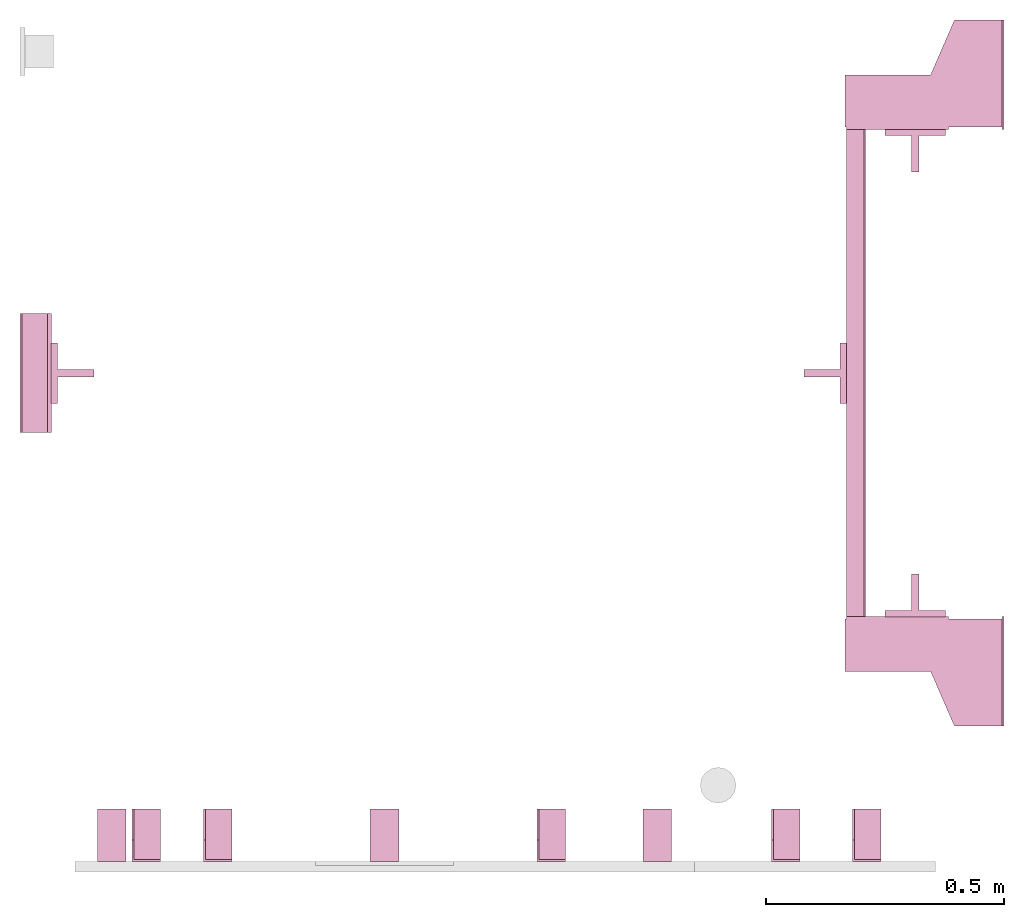
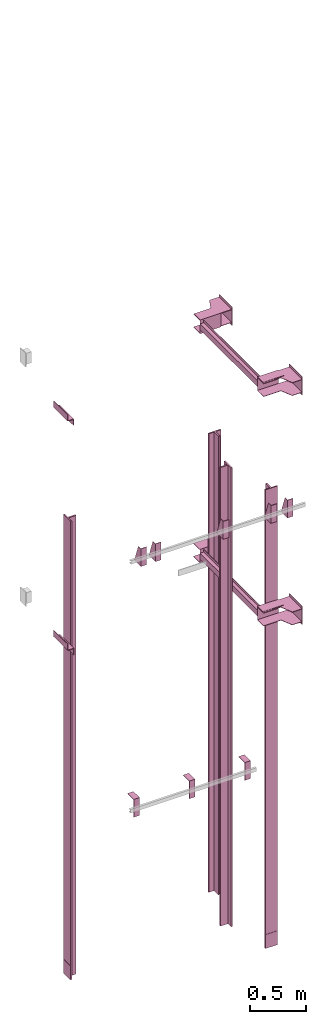
# One storey, part 3 of 3: 16 transport elements.
"""IFC4 building model written with IfcOpenShell, lengths in millimetres."""

from ifc_helpers import new_model, entity, si_unit, converted_unit, frame, origin_with_axes, place, context, subcontext, project, spatial, faceted_brep, element, save


model = new_model("IFC4")

# Units and contexts
context_of_model = context(None, 3, precision=0.01, world=origin_with_axes())
sub_context_1 = subcontext(context_of_model, None, None, "MODEL_VIEW")
sub_context_2 = subcontext(context_of_model, None, None, "MODEL_VIEW")
sub_context_3 = subcontext(context_of_model, None, None, "MODEL_VIEW")
sub_context_4 = subcontext(context_of_model, None, None, "MODEL_VIEW")
sub_context_5 = subcontext(context_of_model, None, None, "MODEL_VIEW")
sub_context_6 = subcontext(context_of_model, None, None, "MODEL_VIEW")
sub_context_7 = subcontext(context_of_model, None, None, "MODEL_VIEW")
sub_context_8 = subcontext(context_of_model, None, None, "MODEL_VIEW")
sub_context_9 = subcontext(context_of_model, None, None, "MODEL_VIEW")
sub_context_10 = subcontext(context_of_model, None, None, "MODEL_VIEW")
sub_context_11 = subcontext(context_of_model, None, None, "MODEL_VIEW")
sub_context_12 = subcontext(context_of_model, None, None, "MODEL_VIEW")
sub_context_13 = subcontext(context_of_model, None, None, "MODEL_VIEW")
sub_context_14 = subcontext(context_of_model, None, None, "MODEL_VIEW")
sub_context_15 = subcontext(context_of_model, None, None, "MODEL_VIEW")
sub_context_16 = subcontext(context_of_model, None, None, "MODEL_VIEW")
ifc_project = project(units=[converted_unit("PLANEANGLEUNIT", "degree", entity("IfcPlaneAngleMeasure", 0.017453292519943), si_unit("PLANEANGLEUNIT", "RADIAN"), dimensions=[0, 0, 0, 0, 0, 0, 0]), si_unit("LENGTHUNIT", "METRE", prefix="MILLI"), si_unit("MASSUNIT", "GRAM", prefix="KILO"), converted_unit("TIMEUNIT", "year", entity("IfcTimeMeasure", 31557600.0), si_unit("TIMEUNIT", "SECOND"), dimensions=[0, 0, 1, 0, 0, 0, 0]), si_unit("THERMODYNAMICTEMPERATUREUNIT", "DEGREE_CELSIUS"), si_unit("AREAUNIT", "SQUARE_METRE"), si_unit("FORCEUNIT", "NEWTON"), si_unit("VOLUMEUNIT", "CUBIC_METRE"), si_unit("PRESSUREUNIT", "PASCAL"), si_unit("SOLIDANGLEUNIT", "STERADIAN")], contexts=[context_of_model])

# Site, building, storey
site = spatial("IfcSite", under=ifc_project)
building = spatial("IfcBuilding", under=site, Name="Document")
placement = place(None, origin_with_axes())
storey_placement = place(placement, frame((0.0, 0.0, -8840.0), z_axis=(0.0, 0.0, 1.0), x_axis=(1.0, 0.0, 0.0)))
storey = spatial("IfcBuildingStorey", under=building, at=storey_placement, Name="-2", Elevation=-8840.0)

# Transport elements
transport_element_1_placement = place(storey_placement, frame((2065.0, 1025.0, 1140.0), z_axis=(0.0, 0.0, 1.0), x_axis=(0.0, 1.0, 0.0)))
element("IfcTransportElement", 1, at=transport_element_1_placement, inside=storey, PredefinedType="ELEVATOR", context=sub_context_1, shape_type="Brep", body=[
    faceted_brep([(-611.0, 331.0, -72.5), (-514.0, 331.0, -72.5), (-514.0, 331.0, 72.5), (-611.0, 331.0, 72.5), (-611.0, 331.0, 75.5), (-511.0, 331.0, 75.5), (-511.0, 331.0, -75.5), (-611.0, 331.0, -75.5), (-511.0, 116.0, -75.5), (-511.0, 116.0, 75.5), (-611.0, 116.0, 75.5), (-611.0, 116.0, 72.5), (-514.0, 116.0, 72.5), (-514.0, 116.0, -72.5), (-611.0, 116.0, -72.5), (-611.0, 116.0, -75.5)], [[[0, 1, 2, 3, 4, 5, 6, 7]], [[8, 9, 10, 11, 12, 13, 14, 15]], [[15, 14, 0, 7]], [[13, 12, 2, 1]], [[5, 9, 8, 6]], [[11, 10, 4, 3]], [[6, 8, 15, 7]], [[14, 13, 1, 0]], [[2, 12, 11, 3]], [[10, 9, 5, 4]]]),
    faceted_brep([(-511.0, 291.0, -32.5), (-511.0, 294.0, -32.5), (-511.0, 294.0, -59.5), (-511.0, 291.0, -59.5), (511.0, 291.0, -32.5), (511.0, 291.0, -59.5), (511.0, 294.0, -59.5), (511.0, 294.0, -32.5)], [[[0, 1, 2, 3]], [[4, 5, 6, 7]], [[0, 3, 5, 4]], [[3, 2, 6, 5]], [[2, 1, 7, 6]], [[1, 0, 4, 7]]]),
    faceted_brep([(-511.0, 291.0, 59.5), (-511.0, 294.0, 59.5), (-511.0, 294.0, 32.5), (-511.0, 291.0, 32.5), (511.0, 291.0, 59.5), (511.0, 291.0, 32.5), (511.0, 294.0, 32.5), (511.0, 294.0, 59.5)], [[[0, 1, 2, 3]], [[4, 5, 6, 7]], [[0, 3, 5, 4]], [[3, 2, 6, 5]], [[2, 1, 7, 6]], [[1, 0, 4, 7]]]),
    faceted_brep([(-511.0, 331.0, 32.5), (511.0, 331.0, 32.5), (511.0, 331.0, -32.5), (-511.0, 331.0, -32.5), (511.0, 328.0, -29.5), (511.0, 328.0, 29.5), (-511.0, 328.0, 29.5), (-511.0, 328.0, -29.5), (511.0, 291.0, -32.5), (511.0, 291.0, -29.5), (-511.0, 291.0, -29.5), (-511.0, 291.0, -32.5), (511.0, 291.0, 29.5), (511.0, 291.0, 32.5), (-511.0, 291.0, 32.5), (-511.0, 291.0, 29.5)], [[[0, 1, 2, 3]], [[4, 5, 6, 7]], [[8, 9, 10, 11]], [[12, 13, 14, 15]], [[11, 10, 7, 6, 15, 14, 0, 3]], [[2, 1, 13, 12, 5, 4, 9, 8]], [[2, 8, 11, 3]], [[10, 9, 4, 7]], [[14, 13, 1, 0]], [[5, 12, 15, 6]]]),
    faceted_brep([(511.0, 331.0, 75.5), (611.0, 331.0, 75.5), (611.0, 331.0, 72.5), (514.0, 331.0, 72.5), (514.0, 331.0, -72.5), (611.0, 331.0, -72.5), (611.0, 331.0, -75.5), (511.0, 331.0, -75.5), (511.0, 116.0, -75.5), (611.0, 116.0, -75.5), (611.0, 116.0, -72.5), (514.0, 116.0, -72.5), (514.0, 116.0, 72.5), (611.0, 116.0, 72.5), (611.0, 116.0, 75.5), (511.0, 116.0, 75.5)], [[[0, 1, 2, 3, 4, 5, 6, 7]], [[8, 9, 10, 11, 12, 13, 14, 15]], [[8, 15, 0, 7]], [[3, 12, 11, 4]], [[5, 10, 9, 6]], [[1, 14, 13, 2]], [[6, 9, 8, 7]], [[11, 10, 5, 4]], [[15, 14, 1, 0]], [[2, 13, 12, 3]]]),
    faceted_brep([(-626.0, 334.0, 72.5), (-516.0, 334.0, 72.5), (-516.0, 334.0, 68.5), (-626.0, 334.0, 68.5), (-516.0, 4.0, 68.5), (-516.0, 4.0, 72.5), (-741.0, 4.0, 72.5), (-741.0, 4.0, 68.5), (-741.0, 104.0, 72.5), (-626.0, 154.0, 72.5), (-626.0, 154.0, 68.5), (-741.0, 104.0, 68.5)], [[[0, 1, 2, 3]], [[4, 5, 6, 7]], [[8, 9, 10, 11]], [[10, 9, 0, 3]], [[1, 5, 4, 2]], [[7, 6, 8, 11]], [[2, 4, 7, 11, 10, 3]], [[9, 8, 6, 5, 1, 0]]]),
    faceted_brep([(516.0, 334.0, 72.5), (626.0, 334.0, 72.5), (626.0, 334.0, 68.5), (516.0, 334.0, 68.5), (741.0, 4.0, 68.5), (741.0, 4.0, 72.5), (516.0, 4.0, 72.5), (516.0, 4.0, 68.5), (626.0, 154.0, 72.5), (741.0, 104.0, 72.5), (741.0, 104.0, 68.5), (626.0, 154.0, 68.5)], [[[0, 1, 2, 3]], [[4, 5, 6, 7]], [[8, 9, 10, 11]], [[7, 6, 0, 3]], [[1, 8, 11, 2]], [[9, 5, 4, 10]], [[2, 11, 10, 4, 7, 3]], [[6, 5, 9, 8, 1, 0]]]),
    faceted_brep([(516.0, 334.0, -68.5), (626.0, 334.0, -68.5), (626.0, 334.0, -72.5), (516.0, 334.0, -72.5), (741.0, 4.0, -72.5), (741.0, 4.0, -68.5), (516.0, 4.0, -68.5), (516.0, 4.0, -72.5), (626.0, 154.0, -68.5), (741.0, 104.0, -68.5), (741.0, 104.0, -72.5), (626.0, 154.0, -72.5)], [[[0, 1, 2, 3]], [[4, 5, 6, 7]], [[8, 9, 10, 11]], [[7, 6, 0, 3]], [[1, 8, 11, 2]], [[9, 5, 4, 10]], [[2, 11, 10, 4, 7, 3]], [[6, 5, 9, 8, 1, 0]]]),
    faceted_brep([(-626.0, 334.0, -68.5), (-516.0, 334.0, -68.5), (-516.0, 334.0, -72.5), (-626.0, 334.0, -72.5), (-516.0, 4.0, -72.5), (-516.0, 4.0, -68.5), (-741.0, 4.0, -68.5), (-741.0, 4.0, -72.5), (-741.0, 104.0, -68.5), (-626.0, 154.0, -68.5), (-626.0, 154.0, -72.5), (-741.0, 104.0, -72.5)], [[[0, 1, 2, 3]], [[4, 5, 6, 7]], [[8, 9, 10, 11]], [[10, 9, 0, 3]], [[1, 5, 4, 2]], [[7, 6, 8, 11]], [[2, 4, 7, 11, 10, 3]], [[9, 8, 6, 5, 1, 0]]]),
    faceted_brep([(-511.0, 0.0, -100.0), (-511.0, 0.0, 100.0), (-741.0, 0.0, 100.0), (-741.0, 0.0, -100.0), (-511.0, 4.0, -100.0), (-741.0, 4.0, -100.0), (-741.0, 4.0, 100.0), (-511.0, 4.0, 100.0)], [[[0, 1, 2, 3]], [[4, 5, 6, 7]], [[0, 3, 5, 4]], [[3, 2, 6, 5]], [[2, 1, 7, 6]], [[1, 0, 4, 7]]]),
    faceted_brep([(741.0, 0.0, -100.0), (741.0, 0.0, 100.0), (511.0, 0.0, 100.0), (511.0, 0.0, -100.0), (741.0, 4.0, -100.0), (511.0, 4.0, -100.0), (511.0, 4.0, 100.0), (741.0, 4.0, 100.0)], [[[0, 1, 2, 3]], [[4, 5, 6, 7]], [[0, 3, 5, 4]], [[3, 2, 6, 5]], [[2, 1, 7, 6]], [[1, 0, 4, 7]]]),
])
transport_element_2_placement = place(storey_placement, frame((2065.0, 1025.0, 3640.0), z_axis=(0.0, 0.0, 1.0), x_axis=(0.0, 1.0, 0.0)))
element("IfcTransportElement", 2, at=transport_element_2_placement, inside=storey, PredefinedType="ELEVATOR", context=sub_context_2, shape_type="Brep", body=[
    faceted_brep([(-611.0, 331.0, -72.5), (-514.0, 331.0, -72.5), (-514.0, 331.0, 72.5), (-611.0, 331.0, 72.5), (-611.0, 331.0, 75.5), (-511.0, 331.0, 75.5), (-511.0, 331.0, -75.5), (-611.0, 331.0, -75.5), (-511.0, 116.0, -75.5), (-511.0, 116.0, 75.5), (-611.0, 116.0, 75.5), (-611.0, 116.0, 72.5), (-514.0, 116.0, 72.5), (-514.0, 116.0, -72.5), (-611.0, 116.0, -72.5), (-611.0, 116.0, -75.5)], [[[0, 1, 2, 3, 4, 5, 6, 7]], [[8, 9, 10, 11, 12, 13, 14, 15]], [[15, 14, 0, 7]], [[13, 12, 2, 1]], [[5, 9, 8, 6]], [[11, 10, 4, 3]], [[6, 8, 15, 7]], [[14, 13, 1, 0]], [[2, 12, 11, 3]], [[10, 9, 5, 4]]]),
    faceted_brep([(-511.0, 331.0, 32.5), (511.0, 331.0, 32.5), (511.0, 331.0, -32.5), (-511.0, 331.0, -32.5), (511.0, 328.0, -29.5), (511.0, 328.0, 29.5), (-511.0, 328.0, 29.5), (-511.0, 328.0, -29.5), (511.0, 291.0, -32.5), (511.0, 291.0, -29.5), (-511.0, 291.0, -29.5), (-511.0, 291.0, -32.5), (511.0, 291.0, 29.5), (511.0, 291.0, 32.5), (-511.0, 291.0, 32.5), (-511.0, 291.0, 29.5)], [[[0, 1, 2, 3]], [[4, 5, 6, 7]], [[8, 9, 10, 11]], [[12, 13, 14, 15]], [[11, 10, 7, 6, 15, 14, 0, 3]], [[2, 1, 13, 12, 5, 4, 9, 8]], [[2, 8, 11, 3]], [[10, 9, 4, 7]], [[14, 13, 1, 0]], [[5, 12, 15, 6]]]),
    faceted_brep([(-511.0, 291.0, -32.5), (-511.0, 294.0, -32.5), (-511.0, 294.0, -59.5), (-511.0, 291.0, -59.5), (511.0, 291.0, -32.5), (511.0, 291.0, -59.5), (511.0, 294.0, -59.5), (511.0, 294.0, -32.5)], [[[0, 1, 2, 3]], [[4, 5, 6, 7]], [[0, 3, 5, 4]], [[3, 2, 6, 5]], [[2, 1, 7, 6]], [[1, 0, 4, 7]]]),
    faceted_brep([(-511.0, 291.0, 59.5), (-511.0, 294.0, 59.5), (-511.0, 294.0, 32.5), (-511.0, 291.0, 32.5), (511.0, 291.0, 59.5), (511.0, 291.0, 32.5), (511.0, 294.0, 32.5), (511.0, 294.0, 59.5)], [[[0, 1, 2, 3]], [[4, 5, 6, 7]], [[0, 3, 5, 4]], [[3, 2, 6, 5]], [[2, 1, 7, 6]], [[1, 0, 4, 7]]]),
    faceted_brep([(511.0, 331.0, 75.5), (611.0, 331.0, 75.5), (611.0, 331.0, 72.5), (514.0, 331.0, 72.5), (514.0, 331.0, -72.5), (611.0, 331.0, -72.5), (611.0, 331.0, -75.5), (511.0, 331.0, -75.5), (511.0, 116.0, -75.5), (611.0, 116.0, -75.5), (611.0, 116.0, -72.5), (514.0, 116.0, -72.5), (514.0, 116.0, 72.5), (611.0, 116.0, 72.5), (611.0, 116.0, 75.5), (511.0, 116.0, 75.5)], [[[0, 1, 2, 3, 4, 5, 6, 7]], [[8, 9, 10, 11, 12, 13, 14, 15]], [[8, 15, 0, 7]], [[3, 12, 11, 4]], [[5, 10, 9, 6]], [[1, 14, 13, 2]], [[6, 9, 8, 7]], [[11, 10, 5, 4]], [[15, 14, 1, 0]], [[2, 13, 12, 3]]]),
    faceted_brep([(516.0, 334.0, -68.5), (626.0, 334.0, -68.5), (626.0, 334.0, -72.5), (516.0, 334.0, -72.5), (741.0, 4.0, -72.5), (741.0, 4.0, -68.5), (516.0, 4.0, -68.5), (516.0, 4.0, -72.5), (626.0, 154.0, -68.5), (741.0, 104.0, -68.5), (741.0, 104.0, -72.5), (626.0, 154.0, -72.5)], [[[0, 1, 2, 3]], [[4, 5, 6, 7]], [[8, 9, 10, 11]], [[7, 6, 0, 3]], [[1, 8, 11, 2]], [[9, 5, 4, 10]], [[2, 11, 10, 4, 7, 3]], [[6, 5, 9, 8, 1, 0]]]),
    faceted_brep([(516.0, 334.0, 72.5), (626.0, 334.0, 72.5), (626.0, 334.0, 68.5), (516.0, 334.0, 68.5), (741.0, 4.0, 68.5), (741.0, 4.0, 72.5), (516.0, 4.0, 72.5), (516.0, 4.0, 68.5), (626.0, 154.0, 72.5), (741.0, 104.0, 72.5), (741.0, 104.0, 68.5), (626.0, 154.0, 68.5)], [[[0, 1, 2, 3]], [[4, 5, 6, 7]], [[8, 9, 10, 11]], [[7, 6, 0, 3]], [[1, 8, 11, 2]], [[9, 5, 4, 10]], [[2, 11, 10, 4, 7, 3]], [[6, 5, 9, 8, 1, 0]]]),
    faceted_brep([(-626.0, 334.0, -68.5), (-516.0, 334.0, -68.5), (-516.0, 334.0, -72.5), (-626.0, 334.0, -72.5), (-516.0, 4.0, -72.5), (-516.0, 4.0, -68.5), (-741.0, 4.0, -68.5), (-741.0, 4.0, -72.5), (-741.0, 104.0, -68.5), (-626.0, 154.0, -68.5), (-626.0, 154.0, -72.5), (-741.0, 104.0, -72.5)], [[[0, 1, 2, 3]], [[4, 5, 6, 7]], [[8, 9, 10, 11]], [[10, 9, 0, 3]], [[1, 5, 4, 2]], [[7, 6, 8, 11]], [[2, 4, 7, 11, 10, 3]], [[9, 8, 6, 5, 1, 0]]]),
    faceted_brep([(-626.0, 334.0, 72.5), (-516.0, 334.0, 72.5), (-516.0, 334.0, 68.5), (-626.0, 334.0, 68.5), (-516.0, 4.0, 68.5), (-516.0, 4.0, 72.5), (-741.0, 4.0, 72.5), (-741.0, 4.0, 68.5), (-741.0, 104.0, 72.5), (-626.0, 154.0, 72.5), (-626.0, 154.0, 68.5), (-741.0, 104.0, 68.5)], [[[0, 1, 2, 3]], [[4, 5, 6, 7]], [[8, 9, 10, 11]], [[10, 9, 0, 3]], [[1, 5, 4, 2]], [[7, 6, 8, 11]], [[2, 4, 7, 11, 10, 3]], [[9, 8, 6, 5, 1, 0]]]),
    faceted_brep([(-511.0, 0.0, -100.0), (-511.0, 0.0, 100.0), (-741.0, 0.0, 100.0), (-741.0, 0.0, -100.0), (-511.0, 4.0, -100.0), (-741.0, 4.0, -100.0), (-741.0, 4.0, 100.0), (-511.0, 4.0, 100.0)], [[[0, 1, 2, 3]], [[4, 5, 6, 7]], [[0, 3, 5, 4]], [[3, 2, 6, 5]], [[2, 1, 7, 6]], [[1, 0, 4, 7]]]),
    faceted_brep([(741.0, 0.0, -100.0), (741.0, 0.0, 100.0), (511.0, 0.0, 100.0), (511.0, 0.0, -100.0), (741.0, 4.0, -100.0), (511.0, 4.0, -100.0), (511.0, 4.0, 100.0), (741.0, 4.0, 100.0)], [[[0, 1, 2, 3]], [[4, 5, 6, 7]], [[0, 3, 5, 4]], [[3, 2, 6, 5]], [[2, 1, 7, 6]], [[1, 0, 4, 7]]]),
])
transport_element_3_placement = place(storey_placement, frame((1879.0, 558.5, -47.0), z_axis=(0.0, -1.0, 0.0), x_axis=(0.0, 0.0, -1.0)))
element("IfcTransportElement", 3, at=transport_element_3_placement, inside=storey, ObjectType="Guide Rail", PredefinedType="ELEVATOR", context=sub_context_3, shape_type="Brep", body=[
    faceted_brep([(2347.5, -63.5, 45.0), (2347.5, 63.5, 45.0), (2347.5, 63.5, 44.0), (2347.5, -63.5, 44.0), (2500.0, -63.5, 45.0), (2500.0, -63.5, 44.0), (2500.0, 63.5, 44.0), (2500.0, 63.5, 45.0)], [[[0, 1, 2, 3]], [[4, 5, 6, 7]], [[0, 3, 5, 4]], [[3, 2, 6, 5]], [[2, 1, 7, 6]], [[1, 0, 4, 7]]]),
    faceted_brep([(-2500.0, -63.5, 45.0), (-2500.0, 63.5, 45.0), (-2500.0, 63.5, 44.0), (-2500.0, -63.5, 44.0), (-2347.5, -63.5, 45.0), (-2347.5, -63.5, 44.0), (-2347.5, 63.5, 44.0), (-2347.5, 63.5, 45.0)], [[[0, 1, 2, 3]], [[4, 5, 6, 7]], [[0, 3, 5, 4]], [[3, 2, 6, 5]], [[2, 1, 7, 6]], [[1, 0, 4, 7]]]),
    faceted_brep([(-2500.0, -63.5, 44.5), (-2500.0, -63.5, 31.79998779296875), (2500.0, -63.5, 31.79998779296875), (2500.0, -63.5, 44.5), (-2500.0, -7.93994140625, 31.79998779296875), (-2500.0, -7.93994140625, -44.5), (2500.0, -7.93994140625, -44.5), (2500.0, -7.93994140625, 31.79998779296875), (2500.0, 7.93994140625, -44.5), (-2500.0, 7.93994140625, -44.5), (-2500.0, 7.93994140625, 31.79998779296875), (2500.0, 7.93994140625, 31.79998779296875), (2500.0, 63.5, 31.79998779296875), (-2500.0, 63.5, 31.79998779296875), (-2500.0, 63.5, 44.5), (2500.0, 63.5, 44.5)], [[[0, 1, 2, 3]], [[4, 5, 6, 7]], [[8, 9, 10, 11]], [[12, 13, 14, 15]], [[15, 14, 0, 3]], [[1, 4, 7, 2]], [[10, 13, 12, 11]], [[5, 9, 8, 6]], [[2, 7, 6, 8, 11, 12, 15, 3]], [[14, 13, 10, 9, 5, 4, 1, 0]]]),
])
transport_element_4_placement = place(storey_placement, frame((1879.0, 1491.5, -47.0), z_axis=(0.0, 1.0, 0.0), x_axis=(0.0, 0.0, 1.0)))
element("IfcTransportElement", 4, at=transport_element_4_placement, inside=storey, ObjectType="Guide Rail", PredefinedType="ELEVATOR", context=sub_context_4, shape_type="Brep", body=[
    faceted_brep([(-2500.0, -63.5, 45.0), (-2500.0, 63.5, 45.0), (-2500.0, 63.5, 44.0), (-2500.0, -63.5, 44.0), (-2347.5, -63.5, 45.0), (-2347.5, -63.5, 44.0), (-2347.5, 63.5, 44.0), (-2347.5, 63.5, 45.0)], [[[0, 1, 2, 3]], [[4, 5, 6, 7]], [[0, 3, 5, 4]], [[3, 2, 6, 5]], [[2, 1, 7, 6]], [[1, 0, 4, 7]]]),
    faceted_brep([(2347.5, -63.5, 45.0), (2347.5, 63.5, 45.0), (2347.5, 63.5, 44.0), (2347.5, -63.5, 44.0), (2500.0, -63.5, 45.0), (2500.0, -63.5, 44.0), (2500.0, 63.5, 44.0), (2500.0, 63.5, 45.0)], [[[0, 1, 2, 3]], [[4, 5, 6, 7]], [[0, 3, 5, 4]], [[3, 2, 6, 5]], [[2, 1, 7, 6]], [[1, 0, 4, 7]]]),
    faceted_brep([(2500.0, -63.5, 31.800048828125), (2500.0, -63.5, 44.5), (-2500.0, -63.5, 44.5), (-2500.0, -63.5, 31.800048828125), (2500.0, -7.93994140625, -44.5), (2500.0, -7.93994140625, 31.800048828125), (-2500.0, -7.93994140625, 31.800048828125), (-2500.0, -7.93994140625, -44.5), (-2500.0, 7.93994140625, 31.800048828125), (2500.0, 7.93994140625, 31.800048828125), (2500.0, 7.93994140625, -44.5), (-2500.0, 7.93994140625, -44.5), (-2500.0, 63.5, 44.5), (2500.0, 63.5, 44.5), (2500.0, 63.5, 31.800048828125), (-2500.0, 63.5, 31.800048828125)], [[[0, 1, 2, 3]], [[4, 5, 6, 7]], [[8, 9, 10, 11]], [[12, 13, 14, 15]], [[6, 5, 0, 3]], [[1, 13, 12, 2]], [[11, 10, 4, 7]], [[9, 8, 15, 14]], [[2, 12, 15, 8, 11, 7, 6, 3]], [[5, 4, 10, 9, 14, 13, 1, 0]]]),
])
transport_element_5_placement = place(storey_placement, frame((110.5, 1025.0, -47.0), z_axis=(-1.0, 0.0, 0.0), x_axis=(0.0, 0.0, -1.0)))
element("IfcTransportElement", 5, at=transport_element_5_placement, inside=storey, ObjectType="Guide Rail", PredefinedType="ELEVATOR", context=sub_context_5, shape_type="Brep", body=[
    faceted_brep([(2347.5, -63.5, 45.0), (2347.5, 63.5, 45.0), (2347.5, 63.5, 44.0), (2347.5, -63.5, 44.0), (2500.0, -63.5, 45.0), (2500.0, -63.5, 44.0), (2500.0, 63.5, 44.0), (2500.0, 63.5, 45.0)], [[[0, 1, 2, 3]], [[4, 5, 6, 7]], [[0, 3, 5, 4]], [[3, 2, 6, 5]], [[2, 1, 7, 6]], [[1, 0, 4, 7]]]),
    faceted_brep([(-2500.0, -63.5, 45.0), (-2500.0, 63.5, 45.0), (-2500.0, 63.5, 44.0), (-2500.0, -63.5, 44.0), (-2347.5, -63.5, 45.0), (-2347.5, -63.5, 44.0), (-2347.5, 63.5, 44.0), (-2347.5, 63.5, 45.0)], [[[0, 1, 2, 3]], [[4, 5, 6, 7]], [[0, 3, 5, 4]], [[3, 2, 6, 5]], [[2, 1, 7, 6]], [[1, 0, 4, 7]]]),
    faceted_brep([(-2500.0, 63.5, 44.5), (-2500.0, -63.5, 44.5), (2500.0, -63.5, 44.5), (2500.0, 63.5, 44.5), (2500.0, 7.94000244140625, 31.800003051757812), (-2500.0, 7.94000244140625, 31.800003051757812), (-2500.0, 63.5, 31.79998779296875), (2500.0, 63.5, 31.79998779296875), (2500.0, -63.5, 31.79998779296875), (-2500.0, -63.5, 31.79998779296875), (-2500.0, -7.93994140625, 31.79998779296875), (2500.0, -7.93994140625, 31.79998779296875), (2500.0, -7.93994140625, -44.5), (-2500.0, -7.93994140625, -44.5), (-2500.0, 7.94000244140625, -44.5), (2500.0, 7.94000244140625, -44.5)], [[[0, 1, 2, 3]], [[4, 5, 6, 7]], [[8, 9, 10, 11]], [[12, 13, 14, 15]], [[7, 6, 0, 3]], [[15, 14, 5, 4]], [[10, 13, 12, 11]], [[1, 9, 8, 2]], [[2, 8, 11, 12, 15, 4, 7, 3]], [[6, 5, 14, 13, 10, 9, 1, 0]]]),
])
transport_element_6_placement = place(storey_placement, frame((1689.5, 1025.0, -47.0), z_axis=(1.0, 0.0, 0.0), x_axis=(0.0, 0.0, 1.0)))
element("IfcTransportElement", 6, at=transport_element_6_placement, inside=storey, ObjectType="Guide Rail", PredefinedType="ELEVATOR", context=sub_context_6, shape_type="Brep", body=[
    faceted_brep([(2347.5, -63.5, 45.0), (2347.5, 63.5, 45.0), (2347.5, 63.5, 44.0), (2347.5, -63.5, 44.0), (2500.0, -63.5, 45.0), (2500.0, -63.5, 44.0), (2500.0, 63.5, 44.0), (2500.0, 63.5, 45.0)], [[[0, 1, 2, 3]], [[4, 5, 6, 7]], [[0, 3, 5, 4]], [[3, 2, 6, 5]], [[2, 1, 7, 6]], [[1, 0, 4, 7]]]),
    faceted_brep([(-2500.0, -63.5, 45.0), (-2500.0, 63.5, 45.0), (-2500.0, 63.5, 44.0), (-2500.0, -63.5, 44.0), (-2347.5, -63.5, 45.0), (-2347.5, -63.5, 44.0), (-2347.5, 63.5, 44.0), (-2347.5, 63.5, 45.0)], [[[0, 1, 2, 3]], [[4, 5, 6, 7]], [[0, 3, 5, 4]], [[3, 2, 6, 5]], [[2, 1, 7, 6]], [[1, 0, 4, 7]]]),
    faceted_brep([(2500.0, 7.94000244140625, -44.5), (2500.0, -7.93994140625, -44.5), (-2500.0, -7.93994140625, -44.5), (-2500.0, 7.94000244140625, -44.5), (2500.0, 63.5, 31.800048828125), (2500.0, 7.94000244140625, 31.800048828125), (-2500.0, 7.94000244140625, 31.800048828125), (-2500.0, 63.5, 31.800048828125), (-2500.0, -63.5, 44.5), (2500.0, -63.5, 44.5), (2500.0, 63.5, 44.5), (-2500.0, 63.5, 44.5), (2500.0, -7.93994140625, 31.800048828125), (2500.0, -63.5, 31.800048828125), (-2500.0, -63.5, 31.800048828125), (-2500.0, -7.93994140625, 31.800048828125)], [[[0, 1, 2, 3]], [[4, 5, 6, 7]], [[8, 9, 10, 11]], [[12, 13, 14, 15]], [[6, 5, 0, 3]], [[1, 12, 15, 2]], [[11, 10, 4, 7]], [[13, 9, 8, 14]], [[2, 15, 14, 8, 11, 7, 6, 3]], [[5, 4, 10, 9, 13, 12, 1, 0]]]),
])
transport_element_7_placement = place(storey_placement, frame((265.0, 0.0, 2580.0), z_axis=(0.0, 0.0, 1.0), x_axis=(1.0, 0.0, 0.0)))
element("IfcTransportElement", 7, at=transport_element_7_placement, inside=storey, PredefinedType="ELEVATOR", context=sub_context_7, shape_type="Brep", body=[
    faceted_brep([(-30.0, 0.0, -97.0), (-30.0, 0.0, 97.0), (-30.0, 4.0, 97.0), (-30.0, 4.0, -93.0), (-30.0, 110.0, -93.0), (-30.0, 110.0, -97.0), (30.0, 110.0, -97.0), (30.0, 110.0, -93.0), (30.0, 4.0, -93.0), (30.0, 4.0, 97.0), (30.0, 0.0, 97.0), (30.0, 0.0, -97.0)], [[[0, 1, 2, 3, 4, 5]], [[6, 7, 8, 9, 10, 11]], [[11, 10, 1, 0]], [[2, 9, 8, 3]], [[4, 7, 6, 5]], [[5, 6, 11, 0]], [[8, 7, 4, 3]], [[10, 9, 2, 1]]]),
    faceted_brep([(-30.0, 4.0, -93.0), (-30.0, 4.0, 97.0), (-30.0, 45.0, 97.0), (-30.0, 110.0, -82.0), (-30.0, 110.0, -93.0), (-26.0, 4.0, -93.0), (-26.0, 110.0, -93.0), (-26.0, 110.0, -82.0), (-26.0, 45.0, 97.0), (-26.0, 4.0, 97.0)], [[[0, 1, 2, 3, 4]], [[5, 6, 7, 8, 9]], [[5, 0, 4, 6]], [[6, 4, 3, 7]], [[7, 3, 2, 8]], [[8, 2, 1, 9]], [[9, 1, 0, 5]]]),
])
transport_element_8_placement = place(storey_placement, frame((415.0, 0.0, 2580.0), z_axis=(0.0, 0.0, 1.0), x_axis=(1.0, 0.0, 0.0)))
element("IfcTransportElement", 8, at=transport_element_8_placement, inside=storey, PredefinedType="ELEVATOR", context=sub_context_8, shape_type="Brep", body=[
    faceted_brep([(-30.0, 0.0, -97.0), (-30.0, 0.0, 97.0), (-30.0, 4.0, 97.0), (-30.0, 4.0, -93.0), (-30.0, 110.0, -93.0), (-30.0, 110.0, -97.0), (30.0, 110.0, -97.0), (30.0, 110.0, -93.0), (30.0, 4.0, -93.0), (30.0, 4.0, 97.0), (30.0, 0.0, 97.0), (30.0, 0.0, -97.0)], [[[0, 1, 2, 3, 4, 5]], [[6, 7, 8, 9, 10, 11]], [[11, 10, 1, 0]], [[2, 9, 8, 3]], [[4, 7, 6, 5]], [[5, 6, 11, 0]], [[8, 7, 4, 3]], [[10, 9, 2, 1]]]),
    faceted_brep([(-30.0, 4.0, -93.0), (-30.0, 4.0, 97.0), (-30.0, 45.0, 97.0), (-30.0, 110.0, -82.0), (-30.0, 110.0, -93.0), (-26.0, 4.0, -93.0), (-26.0, 110.0, -93.0), (-26.0, 110.0, -82.0), (-26.0, 45.0, 97.0), (-26.0, 4.0, 97.0)], [[[0, 1, 2, 3, 4]], [[5, 6, 7, 8, 9]], [[5, 0, 4, 6]], [[6, 4, 3, 7]], [[7, 3, 2, 8]], [[8, 2, 1, 9]], [[9, 1, 0, 5]]]),
])
transport_element_9_placement = place(storey_placement, frame((1115.0, 0.0, 2580.0), z_axis=(0.0, 0.0, 1.0), x_axis=(1.0, 0.0, 0.0)))
element("IfcTransportElement", 9, at=transport_element_9_placement, inside=storey, PredefinedType="ELEVATOR", context=sub_context_9, shape_type="Brep", body=[
    faceted_brep([(-30.0, 0.0, -97.0), (-30.0, 0.0, 97.0), (-30.0, 4.0, 97.0), (-30.0, 4.0, -93.0), (-30.0, 110.0, -93.0), (-30.0, 110.0, -97.0), (30.0, 110.0, -97.0), (30.0, 110.0, -93.0), (30.0, 4.0, -93.0), (30.0, 4.0, 97.0), (30.0, 0.0, 97.0), (30.0, 0.0, -97.0)], [[[0, 1, 2, 3, 4, 5]], [[6, 7, 8, 9, 10, 11]], [[11, 10, 1, 0]], [[2, 9, 8, 3]], [[4, 7, 6, 5]], [[5, 6, 11, 0]], [[8, 7, 4, 3]], [[10, 9, 2, 1]]]),
    faceted_brep([(-30.0, 4.0, -93.0), (-30.0, 4.0, 97.0), (-30.0, 45.0, 97.0), (-30.0, 110.0, -82.0), (-30.0, 110.0, -93.0), (-26.0, 4.0, -93.0), (-26.0, 110.0, -93.0), (-26.0, 110.0, -82.0), (-26.0, 45.0, 97.0), (-26.0, 4.0, 97.0)], [[[0, 1, 2, 3, 4]], [[5, 6, 7, 8, 9]], [[5, 0, 4, 6]], [[6, 4, 3, 7]], [[7, 3, 2, 8]], [[8, 2, 1, 9]], [[9, 1, 0, 5]]]),
])
transport_element_10_placement = place(storey_placement, frame((1607.0, 0.0, 2580.0), z_axis=(0.0, 0.0, 1.0), x_axis=(1.0, 0.0, 0.0)))
element("IfcTransportElement", 10, at=transport_element_10_placement, inside=storey, PredefinedType="ELEVATOR", context=sub_context_10, shape_type="Brep", body=[
    faceted_brep([(-30.0, 4.0, -93.0), (-30.0, 4.0, 97.0), (-30.0, 45.0, 97.0), (-30.0, 110.0, -82.0), (-30.0, 110.0, -93.0), (-26.0, 4.0, -93.0), (-26.0, 110.0, -93.0), (-26.0, 110.0, -82.0), (-26.0, 45.0, 97.0), (-26.0, 4.0, 97.0)], [[[0, 1, 2, 3, 4]], [[5, 6, 7, 8, 9]], [[5, 0, 4, 6]], [[6, 4, 3, 7]], [[7, 3, 2, 8]], [[8, 2, 1, 9]], [[9, 1, 0, 5]]]),
    faceted_brep([(-30.0, 0.0, -97.0), (-30.0, 0.0, 97.0), (-30.0, 4.0, 97.0), (-30.0, 4.0, -93.0), (-30.0, 110.0, -93.0), (-30.0, 110.0, -97.0), (30.0, 110.0, -97.0), (30.0, 110.0, -93.0), (30.0, 4.0, -93.0), (30.0, 4.0, 97.0), (30.0, 0.0, 97.0), (30.0, 0.0, -97.0)], [[[0, 1, 2, 3, 4, 5]], [[6, 7, 8, 9, 10, 11]], [[11, 10, 1, 0]], [[2, 9, 8, 3]], [[4, 7, 6, 5]], [[5, 6, 11, 0]], [[8, 7, 4, 3]], [[10, 9, 2, 1]]]),
])
transport_element_11_placement = place(storey_placement, frame((1777.0, 0.0, 2580.0), z_axis=(0.0, 0.0, 1.0), x_axis=(1.0, 0.0, 0.0)))
element("IfcTransportElement", 11, at=transport_element_11_placement, inside=storey, PredefinedType="ELEVATOR", context=sub_context_11, shape_type="Brep", body=[
    faceted_brep([(-30.0, 0.0, -97.0), (-30.0, 0.0, 97.0), (-30.0, 4.0, 97.0), (-30.0, 4.0, -93.0), (-30.0, 110.0, -93.0), (-30.0, 110.0, -97.0), (30.0, 110.0, -97.0), (30.0, 110.0, -93.0), (30.0, 4.0, -93.0), (30.0, 4.0, 97.0), (30.0, 0.0, 97.0), (30.0, 0.0, -97.0)], [[[0, 1, 2, 3, 4, 5]], [[6, 7, 8, 9, 10, 11]], [[11, 10, 1, 0]], [[2, 9, 8, 3]], [[4, 7, 6, 5]], [[5, 6, 11, 0]], [[8, 7, 4, 3]], [[10, 9, 2, 1]]]),
    faceted_brep([(-30.0, 4.0, -93.0), (-30.0, 4.0, 97.0), (-30.0, 45.0, 97.0), (-30.0, 110.0, -82.0), (-30.0, 110.0, -93.0), (-26.0, 4.0, -93.0), (-26.0, 110.0, -93.0), (-26.0, 110.0, -82.0), (-26.0, 45.0, 97.0), (-26.0, 4.0, 97.0)], [[[0, 1, 2, 3, 4]], [[5, 6, 7, 8, 9]], [[5, 0, 4, 6]], [[6, 4, 3, 7]], [[7, 3, 2, 8]], [[8, 2, 1, 9]], [[9, 1, 0, 5]]]),
])
transport_element_12_placement = place(storey_placement, frame((1337.5, 0.0, -30.0), z_axis=(0.0, 0.0, -1.0), x_axis=(-1.0, 0.0, 0.0)))
element("IfcTransportElement", 12, at=transport_element_12_placement, inside=storey, PredefinedType="ELEVATOR", context=sub_context_12, shape_type="Brep", body=[
    faceted_brep([(-30.0, 4.0, 4.0), (-30.0, 4.0, 194.0), (-30.0, 45.0, 194.0), (-30.0, 110.0, 15.0), (-30.0, 110.0, 4.0), (-26.0, 4.0, 4.0), (-26.0, 110.0, 4.0), (-26.0, 110.0, 15.0), (-26.0, 45.0, 194.0), (-26.0, 4.0, 194.0)], [[[0, 1, 2, 3, 4]], [[5, 6, 7, 8, 9]], [[5, 0, 4, 6]], [[6, 4, 3, 7]], [[7, 3, 2, 8]], [[8, 2, 1, 9]], [[9, 1, 0, 5]]]),
    faceted_brep([(30.0, 0.0, 0.0), (30.0, 110.0, 0.0), (30.0, 110.0, 4.0), (30.0, 4.0, 4.0), (30.0, 4.0, 194.0), (30.0, 0.0, 194.0), (-30.0, 4.0, 194.0), (-30.0, 4.0, 4.0), (-30.0, 110.0, 4.0), (-30.0, 110.0, 0.0), (-30.0, 0.0, 0.0), (-30.0, 0.0, 194.0)], [[[0, 1, 2, 3, 4, 5]], [[6, 7, 8, 9, 10, 11]], [[11, 10, 0, 5]], [[3, 7, 6, 4]], [[1, 9, 8, 2]], [[4, 6, 11, 5]], [[10, 9, 1, 0]], [[2, 8, 7, 3]]]),
])
transport_element_13_placement = place(storey_placement, frame((765.0, 0.0, -30.0), z_axis=(0.0, 0.0, -1.0), x_axis=(-1.0, 0.0, 0.0)))
element("IfcTransportElement", 13, at=transport_element_13_placement, inside=storey, PredefinedType="ELEVATOR", context=sub_context_13, shape_type="Brep", body=[
    faceted_brep([(-30.0, 4.0, 4.0), (-30.0, 4.0, 194.0), (-30.0, 45.0, 194.0), (-30.0, 110.0, 15.0), (-30.0, 110.0, 4.0), (-26.0, 4.0, 4.0), (-26.0, 110.0, 4.0), (-26.0, 110.0, 15.0), (-26.0, 45.0, 194.0), (-26.0, 4.0, 194.0)], [[[0, 1, 2, 3, 4]], [[5, 6, 7, 8, 9]], [[5, 0, 4, 6]], [[6, 4, 3, 7]], [[7, 3, 2, 8]], [[8, 2, 1, 9]], [[9, 1, 0, 5]]]),
    faceted_brep([(30.0, 0.0, 0.0), (30.0, 110.0, 0.0), (30.0, 110.0, 4.0), (30.0, 4.0, 4.0), (30.0, 4.0, 194.0), (30.0, 0.0, 194.0), (-30.0, 4.0, 194.0), (-30.0, 4.0, 4.0), (-30.0, 110.0, 4.0), (-30.0, 110.0, 0.0), (-30.0, 0.0, 0.0), (-30.0, 0.0, 194.0)], [[[0, 1, 2, 3, 4, 5]], [[6, 7, 8, 9, 10, 11]], [[11, 10, 0, 5]], [[3, 7, 6, 4]], [[1, 9, 8, 2]], [[4, 6, 11, 5]], [[10, 9, 1, 0]], [[2, 8, 7, 3]]]),
])
transport_element_14_placement = place(storey_placement, frame((192.5, 0.0, -30.0), z_axis=(0.0, 0.0, -1.0), x_axis=(-1.0, 0.0, 0.0)))
element("IfcTransportElement", 14, at=transport_element_14_placement, inside=storey, PredefinedType="ELEVATOR", context=sub_context_14, shape_type="Brep", body=[
    faceted_brep([(-30.0, 4.0, 4.0), (-30.0, 4.0, 194.0), (-30.0, 45.0, 194.0), (-30.0, 110.0, 15.0), (-30.0, 110.0, 4.0), (-26.0, 4.0, 4.0), (-26.0, 110.0, 4.0), (-26.0, 110.0, 15.0), (-26.0, 45.0, 194.0), (-26.0, 4.0, 194.0)], [[[0, 1, 2, 3, 4]], [[5, 6, 7, 8, 9]], [[5, 0, 4, 6]], [[6, 4, 3, 7]], [[7, 3, 2, 8]], [[8, 2, 1, 9]], [[9, 1, 0, 5]]]),
    faceted_brep([(30.0, 0.0, 0.0), (30.0, 110.0, 0.0), (30.0, 110.0, 4.0), (30.0, 4.0, 4.0), (30.0, 4.0, 194.0), (30.0, 0.0, 194.0), (-30.0, 4.0, 194.0), (-30.0, 4.0, 4.0), (-30.0, 110.0, 4.0), (-30.0, 110.0, 0.0), (-30.0, 0.0, 0.0), (-30.0, 0.0, 194.0)], [[[0, 1, 2, 3, 4, 5]], [[6, 7, 8, 9, 10, 11]], [[11, 10, 0, 5]], [[3, 7, 6, 4]], [[1, 9, 8, 2]], [[4, 6, 11, 5]], [[10, 9, 1, 0]], [[2, 8, 7, 3]]]),
])
transport_element_15_placement = place(storey_placement, frame((0.0, 1025.0, 1140.0), z_axis=(0.0, 0.0, 1.0), x_axis=(0.0, -1.0, 0.0)))
element("IfcTransportElement", 15, at=transport_element_15_placement, inside=storey, PredefinedType="ELEVATOR", context=sub_context_15, shape_type="Brep", body=[
    faceted_brep([(125.0, 8.0, -35.0), (-125.0, 8.0, -35.0), (-125.0, 8.0, -39.0), (125.0, 8.0, -39.0), (125.0, 62.0, -39.0), (-125.0, 62.0, -39.0), (-125.0, 62.0, -105.0), (125.0, 62.0, -105.0), (-125.0, 66.0, -105.0), (-125.0, 66.0, -35.0), (125.0, 66.0, -35.0), (125.0, 66.0, -105.0)], [[[0, 1, 2, 3]], [[4, 5, 6, 7]], [[8, 9, 10, 11]], [[4, 7, 11, 10, 0, 3]], [[1, 9, 8, 6, 5, 2]], [[2, 5, 4, 3]], [[10, 9, 1, 0]], [[6, 8, 11, 7]]]),
    faceted_brep([(125.0, 0.0, 35.0), (-125.0, 0.0, 35.0), (-125.0, 0.0, -35.0), (125.0, 0.0, -35.0), (-125.0, 4.0, -31.0), (-125.0, 4.0, 35.0), (125.0, 4.0, 35.0), (125.0, 4.0, -31.0), (-125.0, 58.0, -35.0), (-125.0, 58.0, -31.0), (125.0, 58.0, -31.0), (125.0, 58.0, -35.0)], [[[0, 1, 2, 3]], [[4, 5, 6, 7]], [[8, 9, 10, 11]], [[11, 10, 7, 6, 0, 3]], [[2, 1, 5, 4, 9, 8]], [[2, 8, 11, 3]], [[10, 9, 4, 7]], [[6, 5, 1, 0]]]),
])
transport_element_16_placement = place(storey_placement, frame((0.0, 1025.0, 3640.0), z_axis=(0.0, 0.0, 1.0), x_axis=(0.0, -1.0, 0.0)))
element("IfcTransportElement", 16, at=transport_element_16_placement, inside=storey, PredefinedType="ELEVATOR", context=sub_context_16, shape_type="Brep", body=[
    faceted_brep([(125.0, 0.0, 35.0), (-125.0, 0.0, 35.0), (-125.0, 0.0, -35.0), (125.0, 0.0, -35.0), (-125.0, 4.0, -31.0), (-125.0, 4.0, 35.0), (125.0, 4.0, 35.0), (125.0, 4.0, -31.0), (-125.0, 58.0, -35.0), (-125.0, 58.0, -31.0), (125.0, 58.0, -31.0), (125.0, 58.0, -35.0)], [[[0, 1, 2, 3]], [[4, 5, 6, 7]], [[8, 9, 10, 11]], [[11, 10, 7, 6, 0, 3]], [[2, 1, 5, 4, 9, 8]], [[2, 8, 11, 3]], [[10, 9, 4, 7]], [[6, 5, 1, 0]]]),
    faceted_brep([(125.0, 8.0, -35.0), (-125.0, 8.0, -35.0), (-125.0, 8.0, -39.0), (125.0, 8.0, -39.0), (125.0, 62.0, -39.0), (-125.0, 62.0, -39.0), (-125.0, 62.0, -105.0), (125.0, 62.0, -105.0), (-125.0, 66.0, -105.0), (-125.0, 66.0, -35.0), (125.0, 66.0, -35.0), (125.0, 66.0, -105.0)], [[[0, 1, 2, 3]], [[4, 5, 6, 7]], [[8, 9, 10, 11]], [[4, 7, 11, 10, 0, 3]], [[1, 9, 8, 6, 5, 2]], [[2, 5, 4, 3]], [[10, 9, 1, 0]], [[6, 8, 11, 7]]]),
])

save(model, "model.ifc")
